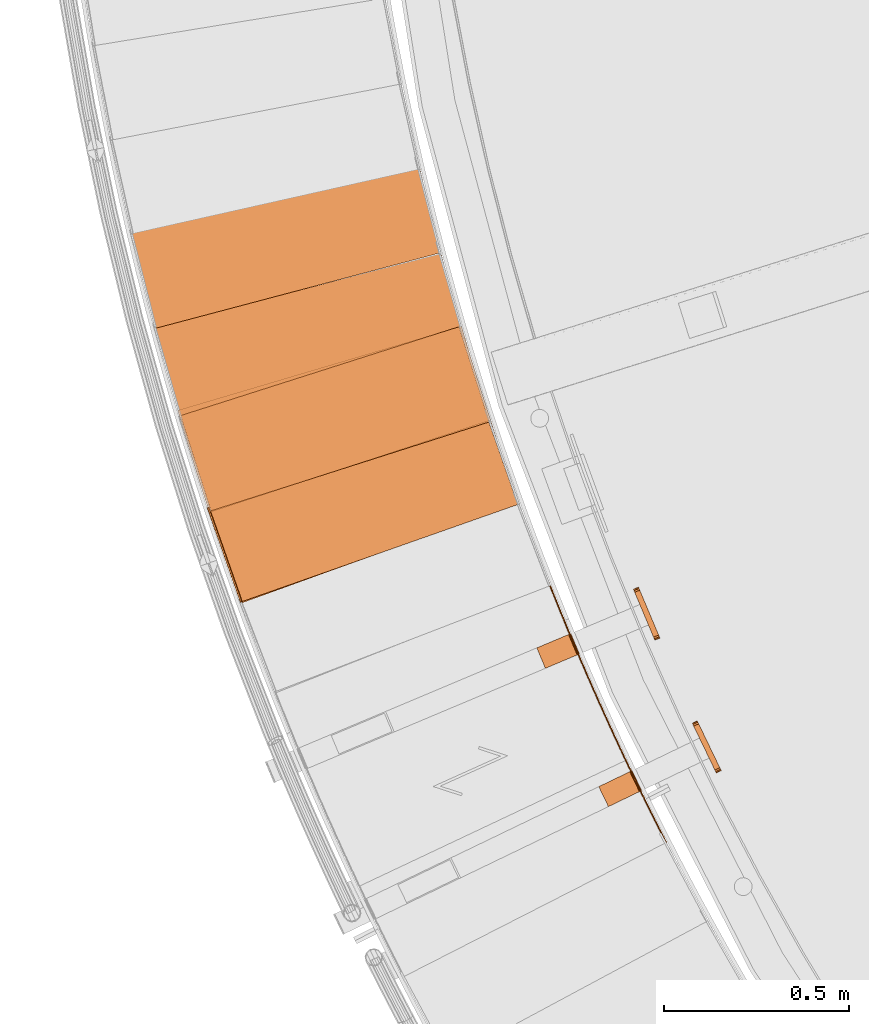
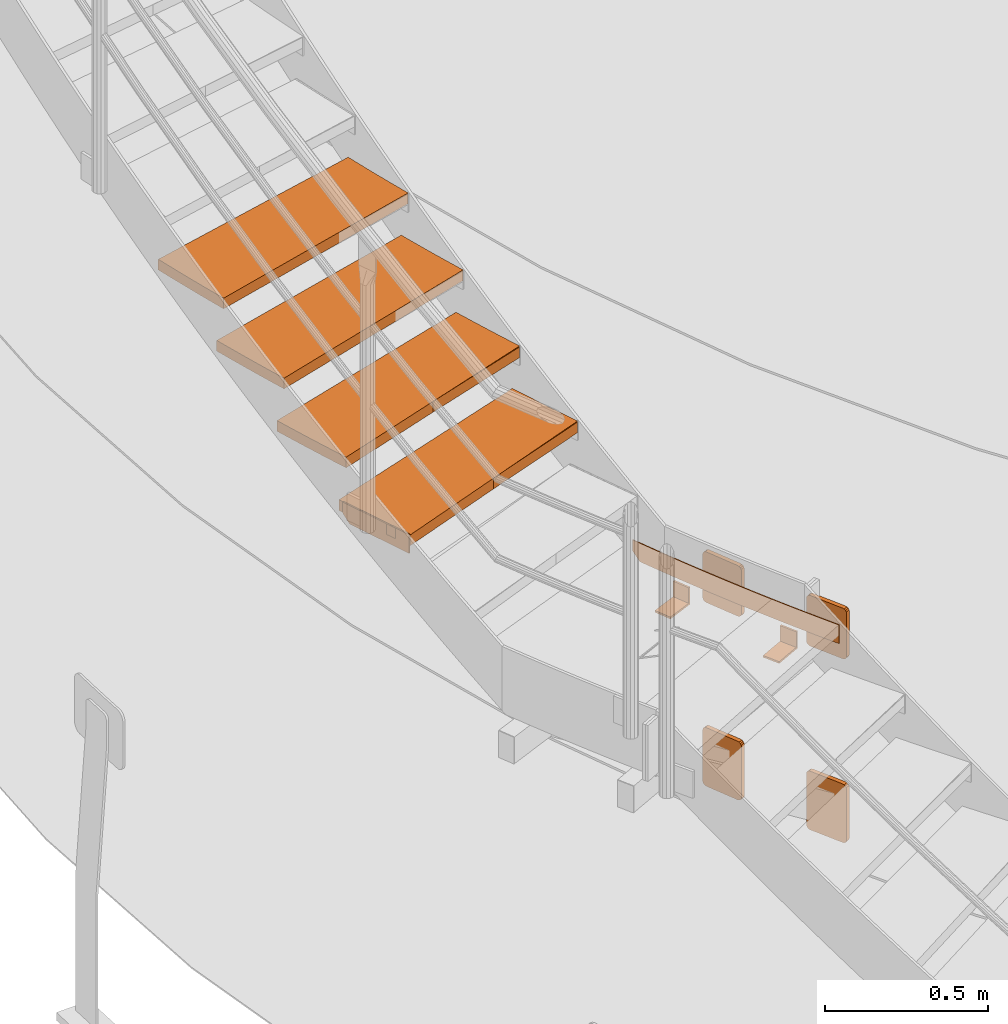
# One storey, part 50 of 126: 14 proxies.
"""IFC2X3 building model written with IfcOpenShell, lengths in millimetres."""

from ifc_helpers import new_model, si_unit, origin, origin_with_axes, place, context, project, spatial, faceted_brep, material, element, save


model = new_model("IFC2X3")

# Units and contexts
context_of_model_1 = context(None, 3, precision=0.1, world=origin())
context_of_model_2 = context(None, 3, precision=0.1, world=origin())
ifc_project = project(units=[si_unit("LENGTHUNIT", "METRE", prefix="MILLI"), si_unit("AREAUNIT", "SQUARE_METRE", prefix="CENTI"), si_unit("VOLUMEUNIT", "CUBIC_METRE", prefix="CENTI"), si_unit("MASSUNIT", "GRAM", prefix="KILO")], contexts=[context_of_model_1, context_of_model_2])

# Site, building, storey
site_placement = place(None, origin_with_axes())
site = spatial("IfcSite", under=ifc_project, at=site_placement, CompositionType="ELEMENT")
building_placement = place(site_placement, origin_with_axes())
building = spatial("IfcBuilding", under=site, at=building_placement, CompositionType="ELEMENT")
storey_placement = place(building_placement, origin_with_axes())
storey = spatial("IfcBuildingStorey", under=building, at=storey_placement, CompositionType="ELEMENT")

# Proxies
ifc_material_1 = material(Name="HOLZ")
proxy_1_placement = place(storey_placement, origin_with_axes())
element("IfcBuildingElementProxy", 1, at=proxy_1_placement, inside=storey, material=ifc_material_1, context=context_of_model_2, shape_type="Brep", body=[
    faceted_brep([(-379.9078, 5278.682, 3117.7125), (-371.731, 5253.6612, 3117.7125), (-363.4796, 5228.6649, 3117.7125), (-355.1536, 5203.6933, 3117.7125), (-346.7531, 5178.7466, 3117.7125), (-338.2782, 5153.8252, 3117.7125), (-329.7288, 5128.9292, 3117.7125), (-321.1052, 5104.0588, 3117.7125), (-312.4074, 5079.2143, 3117.7125), (-303.6355, 5054.3958, 3117.7125), (-294.7895, 5029.6037, 3117.7125), (-285.8695, 5004.838, 3117.7125), (466.3927, 5277.0541, 3117.7125), (457.3829, 5302.0821, 3117.7125), (448.4563, 5327.1398, 3117.7125), (439.6128, 5352.2271, 3117.7125), (430.8525, 5377.3435, 3117.7125), (422.1757, 5402.4889, 3117.7125), (413.5824, 5427.6629, 3117.7125), (405.0726, 5452.8653, 3117.7125), (396.6465, 5478.0958, 3117.7125), (388.3041, 5503.3541, 3117.7125), (380.0456, 5528.64, 3117.7125), (-379.9078, 5278.682, 3077.7125), (380.0456, 5528.64, 3077.7125), (388.3041, 5503.3541, 3077.7125), (396.6465, 5478.0958, 3077.7125), (405.0726, 5452.8653, 3077.7125), (413.5824, 5427.6629, 3077.7125), (422.1757, 5402.4889, 3077.7125), (430.8525, 5377.3435, 3077.7125), (439.6128, 5352.2271, 3077.7125), (448.4563, 5327.1398, 3077.7125), (457.3829, 5302.0821, 3077.7125), (466.3927, 5277.0541, 3077.7125), (-285.8695, 5004.838, 3077.7125), (-294.7895, 5029.6037, 3077.7125), (-303.6355, 5054.3958, 3077.7125), (-312.4074, 5079.2143, 3077.7125), (-321.1052, 5104.0588, 3077.7125), (-329.7288, 5128.9292, 3077.7125), (-338.2782, 5153.8252, 3077.7125), (-346.7531, 5178.7466, 3077.7125), (-355.1536, 5203.6933, 3077.7125), (-363.4796, 5228.6649, 3077.7125), (-371.731, 5253.6612, 3077.7125)], [[[0, 1, 2, 3, 4, 5, 6, 7, 8, 9, 10, 11, 12, 13, 14, 15, 16, 17, 18, 19, 20, 21, 22]], [[23, 24, 25, 26, 27, 28, 29, 30, 31, 32, 33, 34, 35, 36, 37, 38, 39, 40, 41, 42, 43, 44, 45]], [[0, 23, 45, 1]], [[1, 45, 44, 2]], [[2, 44, 43, 3]], [[3, 43, 42, 4]], [[4, 42, 41, 5]], [[5, 41, 40, 6]], [[6, 40, 39, 7]], [[7, 39, 38, 8]], [[8, 38, 37, 9]], [[9, 37, 36, 10]], [[10, 36, 35, 11]], [[11, 35, 34, 12]], [[12, 34, 33, 13]], [[13, 33, 32, 14]], [[14, 32, 31, 15]], [[15, 31, 30, 16]], [[16, 30, 29, 17]], [[17, 29, 28, 18]], [[18, 28, 27, 19]], [[19, 27, 26, 20]], [[20, 26, 25, 21]], [[21, 25, 24, 22]], [[22, 24, 23, 0]]]),
])
proxy_2_placement = place(storey_placement, origin_with_axes())
element("IfcBuildingElementProxy", 2, at=proxy_2_placement, inside=storey, material=ifc_material_1, context=context_of_model_2, shape_type="Brep", body=[
    faceted_brep([(-456.5203, 5526.6613, 3290.9187), (-449.0835, 5501.4106, 3290.9187), (-441.5714, 5476.1823, 3290.9187), (-433.984, 5450.9764, 3290.9187), (-426.3214, 5425.7934, 3290.9187), (-418.5837, 5400.6333, 3290.9187), (-410.7708, 5375.4964, 3290.9187), (-402.883, 5350.383, 3290.9187), (-394.9202, 5325.2932, 3290.9187), (-386.8825, 5300.2273, 3290.9187), (-378.7701, 5275.1855, 3290.9187), (-370.5829, 5250.1681, 3290.9187), (389.3657, 5500.1244, 3290.9187), (381.0964, 5525.4068, 3290.9187), (372.9112, 5550.7164, 3290.9187), (364.8099, 5576.0531, 3290.9187), (356.7928, 5601.4165, 3290.9187), (348.8598, 5626.8063, 3290.9187), (341.0111, 5652.2224, 3290.9187), (333.2468, 5677.6643, 3290.9187), (325.567, 5703.1319, 3290.9187), (317.9717, 5728.6248, 3290.9187), (310.4611, 5754.1428, 3290.9187), (-456.5203, 5526.6613, 3250.9187), (310.4611, 5754.1428, 3250.9187), (317.9717, 5728.6248, 3250.9187), (325.567, 5703.1319, 3250.9187), (333.2468, 5677.6643, 3250.9187), (341.0111, 5652.2224, 3250.9187), (348.8598, 5626.8063, 3250.9187), (356.7928, 5601.4165, 3250.9187), (364.8099, 5576.0531, 3250.9187), (372.9112, 5550.7164, 3250.9187), (381.0964, 5525.4068, 3250.9187), (389.3657, 5500.1244, 3250.9187), (-370.5829, 5250.1681, 3250.9187), (-378.7701, 5275.1855, 3250.9187), (-386.8825, 5300.2273, 3250.9187), (-394.9202, 5325.2932, 3250.9187), (-402.883, 5350.383, 3250.9187), (-410.7708, 5375.4964, 3250.9187), (-418.5837, 5400.6333, 3250.9187), (-426.3214, 5425.7934, 3250.9187), (-433.984, 5450.9764, 3250.9187), (-441.5714, 5476.1823, 3250.9187), (-449.0835, 5501.4106, 3250.9187)], [[[0, 1, 2, 3, 4, 5, 6, 7, 8, 9, 10, 11, 12, 13, 14, 15, 16, 17, 18, 19, 20, 21, 22]], [[23, 24, 25, 26, 27, 28, 29, 30, 31, 32, 33, 34, 35, 36, 37, 38, 39, 40, 41, 42, 43, 44, 45]], [[0, 23, 45, 1]], [[1, 45, 44, 2]], [[2, 44, 43, 3]], [[3, 43, 42, 4]], [[4, 42, 41, 5]], [[5, 41, 40, 6]], [[6, 40, 39, 7]], [[7, 39, 38, 8]], [[8, 38, 37, 9]], [[9, 37, 36, 10]], [[10, 36, 35, 11]], [[11, 35, 34, 12]], [[12, 34, 33, 13]], [[13, 33, 32, 14]], [[14, 32, 31, 15]], [[15, 31, 30, 16]], [[16, 30, 29, 17]], [[17, 29, 28, 18]], [[18, 28, 27, 19]], [[19, 27, 26, 20]], [[20, 26, 25, 21]], [[21, 25, 24, 22]], [[22, 24, 23, 0]]]),
])
proxy_3_placement = place(storey_placement, origin_with_axes())
element("IfcBuildingElementProxy", 3, at=proxy_3_placement, inside=storey, material=ifc_material_1, context=context_of_model_2, shape_type="Brep", body=[
    faceted_brep([(-525.8006, 5776.7882, 3464.125), (-519.1103, 5751.3295, 3464.125), (-512.344, 5725.891, 3464.125), (-505.5018, 5700.4727, 3464.125), (-498.5838, 5675.075, 3464.125), (-491.5899, 5649.6981, 3464.125), (-484.5203, 5624.3422, 3464.125), (-477.3751, 5599.0074, 3464.125), (-470.1542, 5573.6942, 3464.125), (-462.8578, 5548.4026, 3464.125), (-455.486, 5523.1328, 3464.125), (-448.0387, 5497.8853, 3464.125), (318.9377, 5725.3653, 3464.125), (311.4162, 5750.8801, 3464.125), (303.9795, 5776.4197, 3464.125), (296.6275, 5801.9838, 3464.125), (289.3603, 5827.5722, 3464.125), (282.1781, 5853.1845, 3464.125), (275.0809, 5878.8206, 3464.125), (268.0689, 5904.48, 3464.125), (261.142, 5930.1626, 3464.125), (254.3003, 5955.8681, 3464.125), (247.544, 5981.596, 3464.125), (-525.8006, 5776.7882, 3424.125), (247.544, 5981.596, 3424.125), (254.3003, 5955.8681, 3424.125), (261.142, 5930.1626, 3424.125), (268.0689, 5904.48, 3424.125), (275.0809, 5878.8206, 3424.125), (282.1781, 5853.1845, 3424.125), (289.3603, 5827.5722, 3424.125), (296.6275, 5801.9838, 3424.125), (303.9795, 5776.4197, 3424.125), (311.4162, 5750.8801, 3424.125), (318.9377, 5725.3653, 3424.125), (-448.0387, 5497.8853, 3424.125), (-455.486, 5523.1328, 3424.125), (-462.8578, 5548.4026, 3424.125), (-470.1542, 5573.6942, 3424.125), (-477.3751, 5599.0074, 3424.125), (-484.5203, 5624.3422, 3424.125), (-491.5899, 5649.6981, 3424.125), (-498.5838, 5675.075, 3424.125), (-505.5018, 5700.4727, 3424.125), (-512.344, 5725.891, 3424.125), (-519.1103, 5751.3295, 3424.125)], [[[0, 1, 2, 3, 4, 5, 6, 7, 8, 9, 10, 11, 12, 13, 14, 15, 16, 17, 18, 19, 20, 21, 22]], [[23, 24, 25, 26, 27, 28, 29, 30, 31, 32, 33, 34, 35, 36, 37, 38, 39, 40, 41, 42, 43, 44, 45]], [[0, 23, 45, 1]], [[1, 45, 44, 2]], [[2, 44, 43, 3]], [[3, 43, 42, 4]], [[4, 42, 41, 5]], [[5, 41, 40, 6]], [[6, 40, 39, 7]], [[7, 39, 38, 8]], [[8, 38, 37, 9]], [[9, 37, 36, 10]], [[10, 36, 35, 11]], [[11, 35, 34, 12]], [[12, 34, 33, 13]], [[13, 33, 32, 14]], [[14, 32, 31, 15]], [[15, 31, 30, 16]], [[16, 30, 29, 17]], [[17, 29, 28, 18]], [[18, 28, 27, 19]], [[19, 27, 26, 20]], [[20, 26, 25, 21]], [[21, 25, 24, 22]], [[22, 24, 23, 0]]]),
])
proxy_4_placement = place(storey_placement, origin_with_axes())
element("IfcBuildingElementProxy", 4, at=proxy_4_placement, inside=storey, material=ifc_material_1, context=context_of_model_2, shape_type="Brep", body=[
    faceted_brep([(-587.6888, 6028.8458, 3637.3312), (-581.7508, 6003.2012, 3637.3312), (-575.7362, 5977.5746, 3637.3312), (-569.6451, 5951.9659, 3637.3312), (-563.4776, 5926.3756, 3637.3312), (-557.2337, 5900.8038, 3637.3312), (-550.9135, 5875.2508, 3637.3312), (-544.517, 5849.7167, 3637.3312), (-538.0444, 5824.2019, 3637.3312), (-531.4955, 5798.7065, 3637.3312), (-524.8706, 5773.2308, 3637.3312), (-518.1697, 5747.7749, 3637.3312), (255.17, 5952.5815, 3637.3312), (248.4027, 5978.3066, 3637.3312), (241.7209, 6004.054, 3637.3312), (235.1245, 6029.8235, 3637.3312), (228.6137, 6055.6147, 3637.3312), (222.1885, 6081.4274, 3637.3312), (215.8489, 6107.2612, 3637.3312), (209.5951, 6133.1159, 3637.3312), (203.4271, 6158.9913, 3637.3312), (197.3451, 6184.8869, 3637.3312), (191.3489, 6210.8026, 3637.3312), (-587.6888, 6028.8458, 3597.3312), (191.3489, 6210.8026, 3597.3312), (197.3451, 6184.8869, 3597.3312), (203.4271, 6158.9913, 3597.3312), (209.5951, 6133.1159, 3597.3312), (215.8489, 6107.2612, 3597.3312), (222.1885, 6081.4274, 3597.3312), (228.6137, 6055.6147, 3597.3312), (235.1245, 6029.8235, 3597.3312), (241.7209, 6004.054, 3597.3312), (248.4027, 5978.3066, 3597.3312), (255.17, 5952.5815, 3597.3312), (-518.1697, 5747.7749, 3597.3312), (-524.8706, 5773.2308, 3597.3312), (-531.4955, 5798.7065, 3597.3312), (-538.0444, 5824.2019, 3597.3312), (-544.517, 5849.7167, 3597.3312), (-550.9135, 5875.2508, 3597.3312), (-557.2337, 5900.8038, 3597.3312), (-563.4776, 5926.3756, 3597.3312), (-569.6451, 5951.9659, 3597.3312), (-575.7362, 5977.5746, 3597.3312), (-581.7508, 6003.2012, 3597.3312)], [[[0, 1, 2, 3, 4, 5, 6, 7, 8, 9, 10, 11, 12, 13, 14, 15, 16, 17, 18, 19, 20, 21, 22]], [[23, 24, 25, 26, 27, 28, 29, 30, 31, 32, 33, 34, 35, 36, 37, 38, 39, 40, 41, 42, 43, 44, 45]], [[0, 23, 45, 1]], [[1, 45, 44, 2]], [[2, 44, 43, 3]], [[3, 43, 42, 4]], [[4, 42, 41, 5]], [[5, 41, 40, 6]], [[6, 40, 39, 7]], [[7, 39, 38, 8]], [[8, 38, 37, 9]], [[9, 37, 36, 10]], [[10, 36, 35, 11]], [[11, 35, 34, 12]], [[12, 34, 33, 13]], [[13, 33, 32, 14]], [[14, 32, 31, 15]], [[15, 31, 30, 16]], [[16, 30, 29, 17]], [[17, 29, 28, 18]], [[18, 28, 27, 19]], [[19, 27, 26, 20]], [[20, 26, 25, 21]], [[21, 25, 24, 22]], [[22, 24, 23, 0]]]),
])
ifc_material_2 = material(Name="S235JRG2")
proxy_5_placement = place(storey_placement, origin_with_axes())
element("IfcBuildingElementProxy", 5, at=proxy_5_placement, inside=storey, material=ifc_material_2, context=context_of_model_2, shape_type="Brep", body=[
    faceted_brep([(-282.3264, 5009.7847, 3077.67), (-282.3264, 5009.7847, 3117.67), (-371.9803, 5264.4652, 3117.67), (-371.9803, 5264.4652, 3077.67), (462.85, 5272.1055, 3077.67), (373.196, 5526.786, 3077.67), (373.196, 5526.786, 3117.67), (462.85, 5272.1055, 3117.67)], [[[0, 1, 2, 3]], [[4, 5, 6, 7]], [[0, 4, 7, 1]], [[1, 7, 6, 2]], [[2, 6, 5, 3]], [[3, 5, 4, 0]]]),
])
proxy_6_placement = place(storey_placement, origin_with_axes())
element("IfcBuildingElementProxy", 6, at=proxy_6_placement, inside=storey, material=ifc_material_2, context=context_of_model_2, shape_type="Brep", body=[
    faceted_brep([(-287.0427, 5008.1244, 3047.67), (-282.3264, 5009.7847, 3047.67), (-282.3264, 5009.7847, 3117.67), (-287.0427, 5008.1244, 3117.67), (-376.6966, 5262.8049, 3117.67), (-371.9803, 5264.4652, 3117.67), (-371.9803, 5264.4652, 3077.67), (-376.6966, 5262.8049, 3077.67), (-366.7351, 5234.5071, 3047.67), (-362.0188, 5236.1674, 3047.67)], [[[0, 1, 2, 3]], [[4, 5, 6, 7]], [[0, 8, 9, 1]], [[1, 9, 6, 5, 2]], [[2, 5, 4, 3]], [[0, 3, 4, 7, 8]], [[6, 9, 8, 7]]]),
])
proxy_7_placement = place(storey_placement, origin_with_axes())
element("IfcBuildingElementProxy", 7, at=proxy_7_placement, inside=storey, material=ifc_material_2, context=context_of_model_2, shape_type="Brep", body=[
    faceted_brep([(-366.8955, 5255.0076, 3250.83), (-366.8955, 5255.0076, 3290.83), (-449.0145, 5512.2166, 3290.83), (-449.0145, 5512.2166, 3250.83), (385.679, 5495.2816, 3250.83), (303.56, 5752.4906, 3250.83), (303.56, 5752.4906, 3290.83), (385.679, 5495.2816, 3290.83)], [[[0, 1, 2, 3]], [[4, 5, 6, 7]], [[0, 4, 7, 1]], [[1, 7, 6, 2]], [[2, 6, 5, 3]], [[3, 5, 4, 0]]]),
])
proxy_8_placement = place(storey_placement, origin_with_axes())
element("IfcBuildingElementProxy", 8, at=proxy_8_placement, inside=storey, material=ifc_material_2, context=context_of_model_2, shape_type="Brep", body=[
    faceted_brep([(862.3093, 4357.7586, 2701.25), (864.9811, 4359.1228, 2701.25), (864.9811, 4359.1228, 2771.25), (862.3093, 4357.7586, 2771.25), (858.7522, 4364.7248, 2701.25), (861.4254, 4366.0865, 2701.25), (861.4254, 4366.0865, 2771.25), (858.7522, 4364.7248, 2771.25), (851.6653, 4378.6712, 2701.25), (854.3412, 4380.0276, 2701.25), (854.3412, 4380.0276, 2771.25), (851.6653, 4378.6712, 2771.25), (844.6056, 4392.6314, 2701.25), (847.2841, 4393.9826, 2701.25), (847.2841, 4393.9826, 2771.25), (844.6056, 4392.6314, 2771.25), (837.5732, 4406.6053, 2701.25), (840.2543, 4407.9513, 2701.25), (840.2543, 4407.9513, 2771.25), (837.5732, 4406.6053, 2771.25), (830.568, 4420.5929, 2701.25), (833.2517, 4421.9336, 2701.25), (833.2517, 4421.9336, 2771.25), (830.568, 4420.5929, 2771.25), (823.5901, 4434.5941, 2701.25), (826.2764, 4435.9296, 2701.25), (826.2764, 4435.9296, 2771.25), (823.5901, 4434.5941, 2771.25), (816.6395, 4448.6089, 2701.25), (819.3285, 4449.9392, 2701.25), (819.3285, 4449.9392, 2771.25), (816.6395, 4448.6089, 2771.25), (809.7163, 4462.6373, 2701.25), (812.4078, 4463.9623, 2701.25), (812.4078, 4463.9623, 2771.25), (809.7163, 4462.6373, 2771.25), (802.8205, 4476.6791, 2701.25), (805.5146, 4477.9989, 2701.25), (805.5146, 4477.9989, 2771.25), (802.8205, 4476.6791, 2771.25), (795.9521, 4490.7343, 2701.25), (798.6487, 4492.0489, 2701.25), (798.6487, 4492.0489, 2771.25), (795.9521, 4490.7343, 2771.25), (789.1111, 4504.803, 2701.25), (791.8103, 4506.1122, 2701.25), (791.8103, 4506.1122, 2771.25), (789.1111, 4504.803, 2771.25), (782.2975, 4518.8849, 2701.25), (784.9993, 4520.1889, 2701.25), (784.9993, 4520.1889, 2771.25), (782.2975, 4518.8849, 2771.25), (775.5114, 4532.9801, 2701.25), (778.2157, 4534.2788, 2701.25), (778.2157, 4534.2788, 2771.25), (775.5114, 4532.9801, 2771.25), (768.7529, 4547.0885, 2701.25), (771.4597, 4548.382, 2701.25), (771.4597, 4548.382, 2771.25), (768.7529, 4547.0885, 2771.25), (762.0218, 4561.2101, 2701.25), (764.7312, 4562.4983, 2701.25), (764.7312, 4562.4983, 2771.25), (762.0218, 4561.2101, 2771.25), (755.3184, 4575.3448, 2701.25), (758.0302, 4576.6276, 2701.25), (758.0302, 4576.6276, 2771.25), (755.3184, 4575.3448, 2771.25), (748.6425, 4589.4925, 2701.25), (751.3569, 4590.7701, 2701.25), (751.3569, 4590.7701, 2771.25), (748.6425, 4589.4925, 2771.25), (741.9942, 4603.6532, 2701.25), (744.7111, 4604.9255, 2701.25), (744.7111, 4604.9255, 2771.25), (741.9942, 4603.6532, 2771.25), (735.3736, 4617.8268, 2701.25), (738.0929, 4619.0938, 2701.25), (738.0929, 4619.0938, 2771.25), (735.3736, 4617.8268, 2771.25), (728.7806, 4632.0134, 2701.25), (731.5024, 4633.2751, 2701.25), (731.5024, 4633.2751, 2771.25), (728.7806, 4632.0134, 2771.25), (722.2153, 4646.2128, 2701.25), (724.9395, 4647.4691, 2701.25), (724.9395, 4647.4691, 2771.25), (722.2153, 4646.2128, 2771.25), (715.6777, 4660.4249, 2701.25), (718.4044, 4661.676, 2701.25), (718.4044, 4661.676, 2771.25), (715.6777, 4660.4249, 2771.25), (709.1678, 4674.6498, 2701.25), (711.897, 4675.8955, 2701.25), (711.897, 4675.8955, 2771.25), (709.1678, 4674.6498, 2771.25), (702.6857, 4688.8874, 2701.25), (705.4173, 4690.1278, 2701.25), (705.4173, 4690.1278, 2771.25), (702.6857, 4688.8874, 2771.25), (696.2314, 4703.1375, 2701.25), (698.9654, 4704.3726, 2701.25), (698.9654, 4704.3726, 2771.25), (696.2314, 4703.1375, 2771.25), (689.8049, 4717.4003, 2701.25), (692.5413, 4718.63, 2701.25), (692.5413, 4718.63, 2771.25), (689.8049, 4717.4003, 2771.25), (683.4063, 4731.6755, 2701.25), (686.145, 4732.8999, 2701.25), (686.145, 4732.8999, 2771.25), (683.4063, 4731.6755, 2771.25), (677.0354, 4745.9632, 2701.25), (679.7766, 4747.1822, 2701.25), (679.7766, 4747.1822, 2771.25), (677.0354, 4745.9632, 2771.25), (670.6925, 4760.2633, 2701.25), (673.436, 4761.477, 2701.25), (673.436, 4761.477, 2771.25), (670.6925, 4760.2633, 2771.25), (664.3775, 4774.5757, 2701.25), (667.1234, 4775.7841, 2701.25), (667.1234, 4775.7841, 2771.25), (664.3775, 4774.5757, 2771.25), (658.0904, 4788.9004, 2701.25), (660.8386, 4790.1034, 2701.25), (660.8386, 4790.1034, 2771.25), (658.0904, 4788.9004, 2771.25), (651.8312, 4803.2374, 2701.25), (654.5818, 4804.435, 2701.25), (654.5818, 4804.435, 2771.25), (651.8312, 4803.2374, 2771.25), (645.6001, 4817.5866, 2701.25), (648.353, 4818.7788, 2701.25), (648.353, 4818.7788, 2771.25), (645.6001, 4817.5866, 2771.25), (639.3969, 4831.9478, 2701.25), (642.1521, 4833.1347, 2701.25), (642.1521, 4833.1347, 2771.25), (639.3969, 4831.9478, 2771.25), (633.2218, 4846.3212, 2701.25), (635.9793, 4847.5027, 2701.25), (635.9793, 4847.5027, 2771.25), (633.2218, 4846.3212, 2771.25), (627.0747, 4860.7065, 2701.25), (629.8345, 4861.8827, 2701.25), (629.8345, 4861.8827, 2771.25), (627.0747, 4860.7065, 2771.25), (620.9557, 4875.1039, 2701.25), (623.7178, 4876.2746, 2701.25), (623.7178, 4876.2746, 2771.25), (620.9557, 4875.1039, 2771.25), (614.8647, 4889.5131, 2701.25), (617.6291, 4890.6785, 2701.25), (617.6291, 4890.6785, 2771.25), (614.8647, 4889.5131, 2771.25), (608.8019, 4903.9342, 2701.25), (611.5686, 4905.0942, 2701.25), (611.5686, 4905.0942, 2771.25), (608.8019, 4903.9342, 2771.25), (602.7673, 4918.3671, 2701.25), (605.5362, 4919.5217, 2701.25), (605.5362, 4919.5217, 2771.25), (602.7673, 4918.3671, 2771.25), (596.7608, 4932.8117, 2701.25), (599.5319, 4933.9609, 2701.25), (599.5319, 4933.9609, 2771.25), (596.7608, 4932.8117, 2771.25), (590.7824, 4947.268, 2701.25), (593.5558, 4948.4118, 2701.25), (593.5558, 4948.4118, 2771.25), (590.7824, 4947.268, 2771.25), (584.8323, 4961.736, 2701.25), (587.608, 4962.8743, 2701.25), (587.608, 4962.8743, 2771.25), (584.8323, 4961.736, 2771.25), (578.9105, 4976.2155, 2701.25), (581.6883, 4977.3485, 2701.25), (581.6883, 4977.3485, 2771.25), (578.9105, 4976.2155, 2771.25), (573.0168, 4990.7066, 2701.25), (575.7969, 4991.8341, 2701.25), (575.7969, 4991.8341, 2771.25), (573.0168, 4990.7066, 2771.25), (567.1515, 5005.2091, 2701.25), (569.9337, 5006.3312, 2701.25), (569.9337, 5006.3312, 2771.25), (567.1515, 5005.2091, 2771.25), (561.3145, 5019.723, 2701.25), (564.0989, 5020.8397, 2701.25), (564.0989, 5020.8397, 2771.25), (561.3145, 5019.723, 2771.25), (555.5057, 5034.2483, 2701.25), (558.2923, 5035.3596, 2701.25), (558.2923, 5035.3596, 2771.25), (555.5057, 5034.2483, 2771.25), (552.1908, 5042.5849, 2701.25), (554.8744, 5043.9552, 2701.25), (552.5141, 5049.8907, 2707.6096), (552.5141, 5049.8907, 2771.25), (549.7254, 5048.7849, 2771.25), (549.7254, 5048.7849, 2707.893), (546.7643, 5064.4331, 2723.1761), (546.7643, 5064.4331, 2771.25), (543.9733, 5063.3328, 2771.25), (543.9733, 5063.3328, 2723.4653), (543.9035, 5071.7099, 2730.9579), (543.9035, 5071.7099, 2771.25), (541.1115, 5070.6123, 2771.25), (541.1115, 5070.6123, 2731.25)], [[[0, 1, 2, 3]], [[0, 4, 5, 1]], [[1, 5, 6, 2]], [[2, 6, 7, 3]], [[3, 7, 4, 0]], [[4, 8, 9, 5]], [[5, 9, 10, 6]], [[6, 10, 11, 7]], [[7, 11, 8, 4]], [[8, 12, 13, 9]], [[9, 13, 14, 10]], [[10, 14, 15, 11]], [[11, 15, 12, 8]], [[12, 16, 17, 13]], [[13, 17, 18, 14]], [[14, 18, 19, 15]], [[15, 19, 16, 12]], [[16, 20, 21, 17]], [[17, 21, 22, 18]], [[18, 22, 23, 19]], [[19, 23, 20, 16]], [[20, 24, 25, 21]], [[21, 25, 26, 22]], [[22, 26, 27, 23]], [[23, 27, 24, 20]], [[24, 28, 29, 25]], [[25, 29, 30, 26]], [[26, 30, 31, 27]], [[27, 31, 28, 24]], [[28, 32, 33, 29]], [[29, 33, 34, 30]], [[30, 34, 35, 31]], [[31, 35, 32, 28]], [[32, 36, 37, 33]], [[33, 37, 38, 34]], [[34, 38, 39, 35]], [[35, 39, 36, 32]], [[36, 40, 41, 37]], [[37, 41, 42, 38]], [[38, 42, 43, 39]], [[39, 43, 40, 36]], [[40, 44, 45, 41]], [[41, 45, 46, 42]], [[42, 46, 47, 43]], [[43, 47, 44, 40]], [[44, 48, 49, 45]], [[45, 49, 50, 46]], [[46, 50, 51, 47]], [[47, 51, 48, 44]], [[48, 52, 53, 49]], [[49, 53, 54, 50]], [[50, 54, 55, 51]], [[51, 55, 52, 48]], [[52, 56, 57, 53]], [[53, 57, 58, 54]], [[54, 58, 59, 55]], [[55, 59, 56, 52]], [[56, 60, 61, 57]], [[57, 61, 62, 58]], [[58, 62, 63, 59]], [[59, 63, 60, 56]], [[60, 64, 65, 61]], [[61, 65, 66, 62]], [[62, 66, 67, 63]], [[63, 67, 64, 60]], [[64, 68, 69, 65]], [[65, 69, 70, 66]], [[66, 70, 71, 67]], [[67, 71, 68, 64]], [[68, 72, 73, 69]], [[69, 73, 74, 70]], [[70, 74, 75, 71]], [[71, 75, 72, 68]], [[72, 76, 77, 73]], [[73, 77, 78, 74]], [[74, 78, 79, 75]], [[75, 79, 76, 72]], [[76, 80, 81, 77]], [[77, 81, 82, 78]], [[78, 82, 83, 79]], [[79, 83, 80, 76]], [[80, 84, 85, 81]], [[81, 85, 86, 82]], [[82, 86, 87, 83]], [[83, 87, 84, 80]], [[84, 88, 89, 85]], [[85, 89, 90, 86]], [[86, 90, 91, 87]], [[87, 91, 88, 84]], [[88, 92, 93, 89]], [[89, 93, 94, 90]], [[90, 94, 95, 91]], [[91, 95, 92, 88]], [[92, 96, 97, 93]], [[93, 97, 98, 94]], [[94, 98, 99, 95]], [[95, 99, 96, 92]], [[96, 100, 101, 97]], [[97, 101, 102, 98]], [[98, 102, 103, 99]], [[99, 103, 100, 96]], [[100, 104, 105, 101]], [[101, 105, 106, 102]], [[102, 106, 107, 103]], [[103, 107, 104, 100]], [[104, 108, 109, 105]], [[105, 109, 110, 106]], [[106, 110, 111, 107]], [[107, 111, 108, 104]], [[108, 112, 113, 109]], [[109, 113, 114, 110]], [[110, 114, 115, 111]], [[111, 115, 112, 108]], [[112, 116, 117, 113]], [[113, 117, 118, 114]], [[114, 118, 119, 115]], [[115, 119, 116, 112]], [[116, 120, 121, 117]], [[117, 121, 122, 118]], [[118, 122, 123, 119]], [[119, 123, 120, 116]], [[120, 124, 125, 121]], [[121, 125, 126, 122]], [[122, 126, 127, 123]], [[123, 127, 124, 120]], [[124, 128, 129, 125]], [[125, 129, 130, 126]], [[126, 130, 131, 127]], [[127, 131, 128, 124]], [[128, 132, 133, 129]], [[129, 133, 134, 130]], [[130, 134, 135, 131]], [[131, 135, 132, 128]], [[132, 136, 137, 133]], [[133, 137, 138, 134]], [[134, 138, 139, 135]], [[135, 139, 136, 132]], [[136, 140, 141, 137]], [[137, 141, 142, 138]], [[138, 142, 143, 139]], [[139, 143, 140, 136]], [[140, 144, 145, 141]], [[141, 145, 146, 142]], [[142, 146, 147, 143]], [[143, 147, 144, 140]], [[144, 148, 149, 145]], [[145, 149, 150, 146]], [[146, 150, 151, 147]], [[147, 151, 148, 144]], [[148, 152, 153, 149]], [[149, 153, 154, 150]], [[150, 154, 155, 151]], [[151, 155, 152, 148]], [[152, 156, 157, 153]], [[153, 157, 158, 154]], [[154, 158, 159, 155]], [[155, 159, 156, 152]], [[156, 160, 161, 157]], [[157, 161, 162, 158]], [[158, 162, 163, 159]], [[159, 163, 160, 156]], [[160, 164, 165, 161]], [[161, 165, 166, 162]], [[162, 166, 167, 163]], [[163, 167, 164, 160]], [[164, 168, 169, 165]], [[165, 169, 170, 166]], [[166, 170, 171, 167]], [[167, 171, 168, 164]], [[168, 172, 173, 169]], [[169, 173, 174, 170]], [[170, 174, 175, 171]], [[171, 175, 172, 168]], [[172, 176, 177, 173]], [[173, 177, 178, 174]], [[174, 178, 179, 175]], [[175, 179, 176, 172]], [[176, 180, 181, 177]], [[177, 181, 182, 178]], [[178, 182, 183, 179]], [[179, 183, 180, 176]], [[180, 184, 185, 181]], [[181, 185, 186, 182]], [[182, 186, 187, 183]], [[183, 187, 184, 180]], [[184, 188, 189, 185]], [[185, 189, 190, 186]], [[186, 190, 191, 187]], [[187, 191, 188, 184]], [[188, 192, 193, 189]], [[189, 193, 194, 190]], [[190, 194, 195, 191]], [[191, 195, 192, 188]], [[192, 196, 197, 193]], [[193, 197, 198, 199, 194]], [[194, 199, 200, 195]], [[192, 195, 200, 201, 196]], [[198, 202, 203, 199]], [[199, 203, 204, 200]], [[200, 204, 205, 201]], [[203, 202, 206, 207]], [[203, 207, 208, 204]], [[204, 208, 209, 205]], [[207, 206, 209, 208]], [[196, 201, 205, 209, 206, 202, 198, 197]]]),
])
proxy_9_placement = place(storey_placement, origin_with_axes())
element("IfcBuildingElementProxy", 9, at=proxy_9_placement, inside=storey, material=ifc_material_2, context=context_of_model_2, shape_type="Brep", body=[
    faceted_brep([(797.396, 4499.0398, 2686.25), (797.396, 4499.0398, 2621.25), (771.3528, 4553.093, 2621.25), (771.3528, 4553.093, 2686.25), (765.0466, 4550.0547, 2686.25), (791.0898, 4496.0014, 2686.25), (765.0466, 4550.0547, 2628.25), (791.0898, 4496.0014, 2628.25), (681.2641, 4509.6878, 2628.25), (707.3072, 4455.6346, 2628.25), (681.2641, 4509.6878, 2621.25), (707.3072, 4455.6346, 2621.25)], [[[0, 1, 2, 3]], [[0, 3, 4, 5]], [[5, 4, 6, 7]], [[7, 6, 8, 9]], [[9, 8, 10, 11]], [[1, 11, 10, 2]], [[1, 0, 5, 7, 9, 11]], [[3, 2, 10, 8, 6, 4]]]),
])
proxy_10_placement = place(storey_placement, origin_with_axes())
element("IfcBuildingElementProxy", 10, at=proxy_10_placement, inside=storey, material=ifc_material_2, context=context_of_model_2, shape_type="Brep", body=[
    faceted_brep([(953.8345, 4674.3141, 2476.25), (951.3429, 4679.4855, 2477.3918), (949.2307, 4683.8695, 2480.6434), (947.8193, 4686.7988, 2485.5098), (947.3237, 4687.8274, 2491.25), (947.3237, 4687.8274, 2651.25), (947.8193, 4686.7988, 2656.9903), (949.2307, 4683.8695, 2661.8566), (951.3429, 4679.4855, 2665.1082), (953.8345, 4674.3141, 2666.25), (1005.9208, 4566.2076, 2666.25), (1008.4123, 4561.0363, 2665.1082), (1010.5246, 4556.6522, 2661.8566), (1011.9359, 4553.7229, 2656.9903), (1012.4315, 4552.6943, 2651.25), (1012.4315, 4552.6943, 2491.25), (1011.9359, 4553.7229, 2485.5098), (1010.5246, 4556.6522, 2480.6434), (1008.4123, 4561.0363, 2477.3918), (1005.9208, 4566.2076, 2476.25), (940.3212, 4667.8033, 2476.25), (992.4074, 4559.6968, 2476.25), (994.899, 4554.5255, 2477.3918), (997.0113, 4550.1415, 2480.6434), (998.4226, 4547.2121, 2485.5098), (998.9182, 4546.1835, 2491.25), (998.9182, 4546.1835, 2651.25), (998.4226, 4547.2121, 2656.9903), (997.0113, 4550.1415, 2661.8566), (994.899, 4554.5255, 2665.1082), (992.4074, 4559.6968, 2666.25), (940.3212, 4667.8033, 2666.25), (937.8296, 4672.9747, 2665.1082), (935.7174, 4677.3587, 2661.8566), (934.306, 4680.288, 2656.9903), (933.8104, 4681.3167, 2651.25), (933.8104, 4681.3167, 2491.25), (934.306, 4680.288, 2485.5098), (935.7174, 4677.3587, 2480.6434), (937.8296, 4672.9747, 2477.3918)], [[[0, 1, 2, 3, 4, 5, 6, 7, 8, 9, 10, 11, 12, 13, 14, 15, 16, 17, 18, 19]], [[20, 21, 22, 23, 24, 25, 26, 27, 28, 29, 30, 31, 32, 33, 34, 35, 36, 37, 38, 39]], [[0, 20, 39, 1]], [[1, 39, 38, 2]], [[2, 38, 37, 3]], [[3, 37, 36, 4]], [[4, 36, 35, 5]], [[5, 35, 34, 6]], [[6, 34, 33, 7]], [[7, 33, 32, 8]], [[8, 32, 31, 9]], [[9, 31, 30, 10]], [[10, 30, 29, 11]], [[11, 29, 28, 12]], [[12, 28, 27, 13]], [[13, 27, 26, 14]], [[14, 26, 25, 15]], [[15, 25, 24, 16]], [[16, 24, 23, 17]], [[17, 23, 22, 18]], [[18, 22, 21, 19]], [[19, 21, 20, 0]]]),
])
proxy_11_placement = place(storey_placement, origin_with_axes())
element("IfcBuildingElementProxy", 11, at=proxy_11_placement, inside=storey, material=ifc_material_2, context=context_of_model_2, shape_type="Brep", body=[
    faceted_brep([(629.2495, 4868.1836, 2686.25), (629.2495, 4868.1836, 2621.25), (605.9744, 4923.4852, 2621.25), (605.9744, 4923.4852, 2686.25), (599.5226, 4920.7698, 2686.25), (622.7976, 4865.4681, 2686.25), (599.5226, 4920.7698, 2628.25), (622.7976, 4865.4681, 2628.25), (513.805, 4884.6934, 2628.25), (537.0801, 4829.3918, 2628.25), (513.805, 4884.6934, 2621.25), (537.0801, 4829.3918, 2621.25)], [[[0, 1, 2, 3]], [[0, 3, 4, 5]], [[5, 4, 6, 7]], [[7, 6, 8, 9]], [[9, 8, 10, 11]], [[1, 11, 10, 2]], [[1, 0, 5, 7, 9, 11]], [[3, 2, 10, 8, 6, 4]]]),
])
proxy_12_placement = place(storey_placement, origin_with_axes())
element("IfcBuildingElementProxy", 12, at=proxy_12_placement, inside=storey, material=ifc_material_2, context=context_of_model_2, shape_type="Brep", body=[
    faceted_brep([(794.3554, 5035.3188, 2476.25), (792.1286, 5040.6095, 2477.3918), (790.2409, 5045.0948, 2480.6434), (788.9795, 5048.0918, 2485.5098), (788.5366, 5049.1442, 2491.25), (788.5366, 5049.1442, 2651.25), (788.9795, 5048.0918, 2656.9903), (790.2409, 5045.0948, 2661.8566), (792.1286, 5040.6095, 2665.1082), (794.3554, 5035.3188, 2666.25), (840.9055, 4924.7155, 2666.25), (843.1322, 4919.4247, 2665.1082), (845.02, 4914.9394, 2661.8566), (846.2813, 4911.9425, 2656.9903), (846.7243, 4910.8901, 2651.25), (846.7243, 4910.8901, 2491.25), (846.2813, 4911.9425, 2485.5098), (845.02, 4914.9394, 2480.6434), (843.1322, 4919.4247, 2477.3918), (840.9055, 4924.7155, 2476.25), (780.53, 5029.5, 2476.25), (827.0801, 4918.8967, 2476.25), (829.3068, 4913.606, 2477.3918), (831.1946, 4909.1207, 2480.6434), (832.4559, 4906.1237, 2485.5098), (832.8989, 4905.0713, 2491.25), (832.8989, 4905.0713, 2651.25), (832.4559, 4906.1237, 2656.9903), (831.1946, 4909.1207, 2661.8566), (829.3068, 4913.606, 2665.1082), (827.0801, 4918.8967, 2666.25), (780.53, 5029.5, 2666.25), (778.3032, 5034.7907, 2665.1082), (776.4155, 5039.276, 2661.8566), (775.1541, 5042.273, 2656.9903), (774.7112, 5043.3254, 2651.25), (774.7112, 5043.3254, 2491.25), (775.1541, 5042.273, 2485.5098), (776.4155, 5039.276, 2480.6434), (778.3032, 5034.7907, 2477.3918)], [[[0, 1, 2, 3, 4, 5, 6, 7, 8, 9, 10, 11, 12, 13, 14, 15, 16, 17, 18, 19]], [[20, 21, 22, 23, 24, 25, 26, 27, 28, 29, 30, 31, 32, 33, 34, 35, 36, 37, 38, 39]], [[0, 20, 39, 1]], [[1, 39, 38, 2]], [[2, 38, 37, 3]], [[3, 37, 36, 4]], [[4, 36, 35, 5]], [[5, 35, 34, 6]], [[6, 34, 33, 7]], [[7, 33, 32, 8]], [[8, 32, 31, 9]], [[9, 31, 30, 10]], [[10, 30, 29, 11]], [[11, 29, 28, 12]], [[12, 28, 27, 13]], [[13, 27, 26, 14]], [[14, 26, 25, 15]], [[15, 25, 24, 16]], [[16, 24, 23, 17]], [[17, 23, 22, 18]], [[18, 22, 21, 19]], [[19, 21, 20, 0]]]),
])
proxy_13_placement = place(storey_placement, origin_with_axes())
element("IfcBuildingElementProxy", 13, at=proxy_13_placement, inside=storey, material=ifc_material_2, context=context_of_model_2, shape_type="Brep", body=[
    faceted_brep([(794.3554, 5035.3188, 1787.0657), (792.1286, 5040.6095, 1788.2075), (790.2409, 5045.0948, 1791.4591), (788.9795, 5048.0918, 1796.3255), (788.5366, 5049.1442, 1802.0657), (788.5366, 5049.1442, 1992.0657), (788.9795, 5048.0918, 1997.806), (790.2409, 5045.0948, 2002.6723), (792.1286, 5040.6095, 2005.9239), (794.3554, 5035.3188, 2007.0657), (840.9055, 4924.7155, 2007.0657), (843.1322, 4919.4247, 2005.9239), (845.02, 4914.9394, 2002.6723), (846.2813, 4911.9425, 1997.806), (846.7243, 4910.8901, 1992.0657), (846.7243, 4910.8901, 1802.0657), (846.2813, 4911.9425, 1796.3255), (845.02, 4914.9394, 1791.4591), (843.1322, 4919.4247, 1788.2075), (840.9055, 4924.7155, 1787.0657), (780.53, 5029.5, 1787.0657), (827.0801, 4918.8967, 1787.0657), (829.3068, 4913.606, 1788.2075), (831.1946, 4909.1207, 1791.4591), (832.4559, 4906.1237, 1796.3255), (832.8989, 4905.0713, 1802.0657), (832.8989, 4905.0713, 1992.0657), (832.4559, 4906.1237, 1997.806), (831.1946, 4909.1207, 2002.6723), (829.3068, 4913.606, 2005.9239), (827.0801, 4918.8967, 2007.0657), (780.53, 5029.5, 2007.0657), (778.3032, 5034.7907, 2005.9239), (776.4155, 5039.276, 2002.6723), (775.1541, 5042.273, 1997.806), (774.7112, 5043.3254, 1992.0657), (774.7112, 5043.3254, 1802.0657), (775.1541, 5042.273, 1796.3255), (776.4155, 5039.276, 1791.4591), (778.3032, 5034.7907, 1788.2075)], [[[0, 1, 2, 3, 4, 5, 6, 7, 8, 9, 10, 11, 12, 13, 14, 15, 16, 17, 18, 19]], [[20, 21, 22, 23, 24, 25, 26, 27, 28, 29, 30, 31, 32, 33, 34, 35, 36, 37, 38, 39]], [[0, 20, 39, 1]], [[1, 39, 38, 2]], [[2, 38, 37, 3]], [[3, 37, 36, 4]], [[4, 36, 35, 5]], [[5, 35, 34, 6]], [[6, 34, 33, 7]], [[7, 33, 32, 8]], [[8, 32, 31, 9]], [[9, 31, 30, 10]], [[10, 30, 29, 11]], [[11, 29, 28, 12]], [[12, 28, 27, 13]], [[13, 27, 26, 14]], [[14, 26, 25, 15]], [[15, 25, 24, 16]], [[16, 24, 23, 17]], [[17, 23, 22, 18]], [[18, 22, 21, 19]], [[19, 21, 20, 0]]]),
])
proxy_14_placement = place(storey_placement, origin_with_axes())
element("IfcBuildingElementProxy", 14, at=proxy_14_placement, inside=storey, material=ifc_material_2, context=context_of_model_2, shape_type="Brep", body=[
    faceted_brep([(953.8345, 4674.3141, 1787.0657), (951.343, 4679.4855, 1788.2075), (949.2307, 4683.8695, 1791.4591), (947.8194, 4686.7988, 1796.3255), (947.3237, 4687.8275, 1802.0657), (947.3237, 4687.8275, 1992.0657), (947.8194, 4686.7988, 1997.806), (949.2307, 4683.8695, 2002.6723), (951.343, 4679.4855, 2005.9239), (953.8345, 4674.3141, 2007.0657), (1005.9208, 4566.2076, 2007.0657), (1008.4124, 4561.0363, 2005.9239), (1010.5246, 4556.6523, 2002.6723), (1011.936, 4553.7229, 1997.806), (1012.4316, 4552.6943, 1992.0657), (1012.4316, 4552.6943, 1802.0657), (1011.936, 4553.7229, 1796.3255), (1010.5246, 4556.6523, 1791.4591), (1008.4124, 4561.0363, 1788.2075), (1005.9208, 4566.2076, 1787.0657), (940.3212, 4667.8034, 1787.0657), (992.4075, 4559.6968, 1787.0657), (994.899, 4554.5255, 1788.2075), (997.0113, 4550.1415, 1791.4591), (998.4227, 4547.2122, 1796.3255), (998.9183, 4546.1835, 1802.0657), (998.9183, 4546.1835, 1992.0657), (998.4227, 4547.2122, 1997.806), (997.0113, 4550.1415, 2002.6723), (994.899, 4554.5255, 2005.9239), (992.4075, 4559.6968, 2007.0657), (940.3212, 4667.8034, 2007.0657), (937.8296, 4672.9747, 2005.9239), (935.7174, 4677.3587, 2002.6723), (934.306, 4680.288, 1997.806), (933.8104, 4681.3167, 1992.0657), (933.8104, 4681.3167, 1802.0657), (934.306, 4680.288, 1796.3255), (935.7174, 4677.3587, 1791.4591), (937.8296, 4672.9747, 1788.2075)], [[[0, 1, 2, 3, 4, 5, 6, 7, 8, 9, 10, 11, 12, 13, 14, 15, 16, 17, 18, 19]], [[20, 21, 22, 23, 24, 25, 26, 27, 28, 29, 30, 31, 32, 33, 34, 35, 36, 37, 38, 39]], [[0, 20, 39, 1]], [[1, 39, 38, 2]], [[2, 38, 37, 3]], [[3, 37, 36, 4]], [[4, 36, 35, 5]], [[5, 35, 34, 6]], [[6, 34, 33, 7]], [[7, 33, 32, 8]], [[8, 32, 31, 9]], [[9, 31, 30, 10]], [[10, 30, 29, 11]], [[11, 29, 28, 12]], [[12, 28, 27, 13]], [[13, 27, 26, 14]], [[14, 26, 25, 15]], [[15, 25, 24, 16]], [[16, 24, 23, 17]], [[17, 23, 22, 18]], [[18, 22, 21, 19]], [[19, 21, 20, 0]]]),
])

save(model, "model.ifc")
